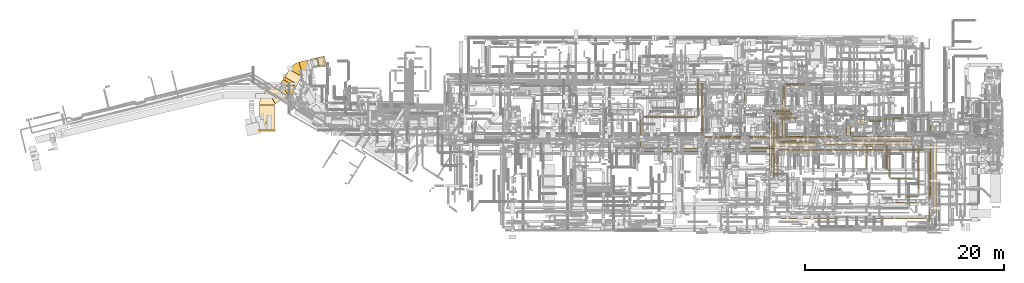
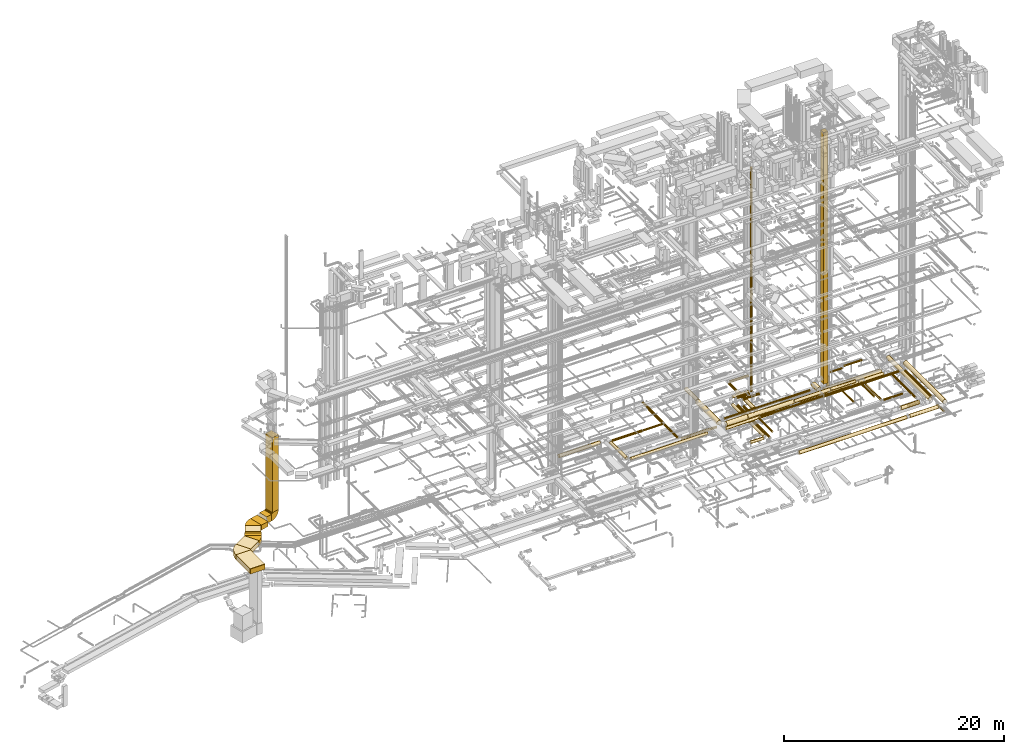
# One storey, part 1 of 337: 65 coverings.
"""IFC2X3 building model written with IfcOpenShell, lengths in millimetres."""

from ifc_helpers import new_model, entity, si_unit, converted_unit, derived_unit, direction, frame, frame_2d, origin, origin_2d_with_axis, place, context, subcontext, project, spatial, polyline, circle_curve, parameter, trimmed, segment, composite_curve, rectangle, circle, outline, extrude, element, save


model = new_model("IFC2X3")

# Units and contexts
model_context = context("Model", 3, precision=0.01, world=origin(), true_north=direction((6.12303176911189e-17, 1.0)))
body_context = subcontext(model_context, "Body", "Model", "MODEL_VIEW")
ifc_project = project(units=[si_unit("LENGTHUNIT", "METRE", prefix="MILLI"), si_unit("AREAUNIT", "SQUARE_METRE"), si_unit("VOLUMEUNIT", "CUBIC_METRE"), converted_unit("PLANEANGLEUNIT", "DEGREE", entity("IfcRatioMeasure", 0.0174532925199433), si_unit("PLANEANGLEUNIT", "RADIAN"), dimensions=[0, 0, 0, 0, 0, 0, 0]), si_unit("MASSUNIT", "GRAM", prefix="KILO"), derived_unit("MASSDENSITYUNIT", [(si_unit("MASSUNIT", "GRAM", prefix="KILO"), 1), (si_unit("LENGTHUNIT", "METRE"), -3)]), derived_unit("MOMENTOFINERTIAUNIT", [(si_unit("LENGTHUNIT", "METRE"), 4)]), si_unit("TIMEUNIT", "SECOND"), si_unit("FREQUENCYUNIT", "HERTZ"), si_unit("THERMODYNAMICTEMPERATUREUNIT", "DEGREE_CELSIUS"), derived_unit("THERMALTRANSMITTANCEUNIT", [(si_unit("MASSUNIT", "GRAM", prefix="KILO"), 1), (si_unit("THERMODYNAMICTEMPERATUREUNIT", "KELVIN"), -1), (si_unit("TIMEUNIT", "SECOND"), -3)]), derived_unit("VOLUMETRICFLOWRATEUNIT", [(si_unit("LENGTHUNIT", "METRE"), 3), (si_unit("TIMEUNIT", "SECOND"), -1)]), derived_unit("MASSFLOWRATEUNIT", [(si_unit("MASSUNIT", "GRAM", prefix="KILO"), 1), (si_unit("TIMEUNIT", "SECOND"), -1)]), derived_unit("ROTATIONALFREQUENCYUNIT", [(si_unit("TIMEUNIT", "SECOND"), -1)]), si_unit("ELECTRICCURRENTUNIT", "AMPERE"), si_unit("ELECTRICVOLTAGEUNIT", "VOLT"), si_unit("POWERUNIT", "WATT"), si_unit("FORCEUNIT", "NEWTON", prefix="KILO"), si_unit("ILLUMINANCEUNIT", "LUX"), si_unit("LUMINOUSFLUXUNIT", "LUMEN"), si_unit("LUMINOUSINTENSITYUNIT", "CANDELA"), derived_unit("USERDEFINED", [(si_unit("MASSUNIT", "GRAM", prefix="KILO"), -1), (si_unit("LENGTHUNIT", "METRE"), -2), (si_unit("TIMEUNIT", "SECOND"), 3), (si_unit("LUMINOUSFLUXUNIT", "LUMEN"), 1)]), derived_unit("LINEARVELOCITYUNIT", [(si_unit("LENGTHUNIT", "METRE"), 1), (si_unit("TIMEUNIT", "SECOND"), -1)]), si_unit("PRESSUREUNIT", "PASCAL"), derived_unit("USERDEFINED", [(si_unit("LENGTHUNIT", "METRE"), -2), (si_unit("MASSUNIT", "GRAM", prefix="KILO"), 1), (si_unit("TIMEUNIT", "SECOND"), -2)]), derived_unit("LINEARFORCEUNIT", [(si_unit("MASSUNIT", "GRAM", prefix="KILO"), 1), (si_unit("LENGTHUNIT", "METRE"), 1), (si_unit("TIMEUNIT", "SECOND"), -2), (si_unit("LENGTHUNIT", "METRE"), -1)]), derived_unit("PLANARFORCEUNIT", [(si_unit("MASSUNIT", "GRAM", prefix="KILO"), 1), (si_unit("LENGTHUNIT", "METRE"), 1), (si_unit("TIMEUNIT", "SECOND"), -2), (si_unit("LENGTHUNIT", "METRE"), -2)])], contexts=[model_context])

# Site, building, storey
site_placement = place(None, origin())
site = spatial("IfcSite", under=ifc_project, at=site_placement, CompositionType="ELEMENT")
building_placement = place(site_placement, origin())
building = spatial("IfcBuilding", under=site, at=building_placement, CompositionType="ELEMENT")
storey_placement = place(building_placement, origin())
storey = spatial("IfcBuildingStorey", under=building, at=storey_placement, CompositionType="ELEMENT", Elevation=0.0)

# Coverings
covering_1_placement = place(storey_placement, frame((31730.09, 12340.89, 3115.9)))
element("IfcCovering", 1, at=covering_1_placement, inside=storey, PredefinedType="INSULATION", context=body_context, shape_type="SweptSolid", body=[
    extrude(circle(Radius=182.5, at=origin_2d_with_axis()), frame((0.0, 184.1, 184.1), z_axis=(1.0, 0.0, 0.0), x_axis=(0.0, -1.0, 0.0)), (0.0, 0.0, 1.0), 4313.00282220616),
])
covering_2_placement = place(storey_placement, frame((46976.82, 8435.07, 3273.4)))
element("IfcCovering", 2, at=covering_2_placement, inside=storey, PredefinedType="INSULATION", context=body_context, shape_type="SweptSolid", body=[
    extrude(circle(Radius=150.0, at=origin_2d_with_axis()), frame((0.0, 151.6, 151.6), z_axis=(1.0, 0.0, 0.0), x_axis=(0.0, -1.0, 0.0)), (0.0, 0.0, 1.0), 3554.57947317912),
])
covering_3_placement = place(storey_placement, frame((50581.4, 8460.07, 3273.4)))
element("IfcCovering", 3, at=covering_3_placement, inside=storey, PredefinedType="INSULATION", context=body_context, shape_type="SweptSolid", body=[
    extrude(circle(Radius=125.0, at=origin_2d_with_axis()), frame((0.0, 126.6, 126.6), z_axis=(1.0, 0.0, 0.0), x_axis=(0.0, 1.0, 0.0)), (0.0, 0.0, 1.0), 14575.0),
])
covering_4_placement = place(storey_placement, frame((36592.96, 8836.67, 3398.4)))
element("IfcCovering", 4, at=covering_4_placement, inside=storey, PredefinedType="INSULATION", context=body_context, shape_type="SweptSolid", body=[
    extrude(circle(Radius=150.0, at=origin_2d_with_axis()), frame((151.6, 0.0, 151.6), z_axis=(0.0, 1.0, 0.0), x_axis=(-1.0, 0.0, 0.0)), (0.0, 0.0, 1.0), 2863.31900942015),
])
covering_5_placement = place(storey_placement, frame((36994.56, 8435.07, 3398.4)))
element("IfcCovering", 5, at=covering_5_placement, inside=storey, PredefinedType="INSULATION", context=body_context, shape_type="SweptSolid", body=[
    extrude(circle(Radius=150.0, at=origin_2d_with_axis()), frame((0.0, 151.6, 151.6), z_axis=(1.0, 0.0, 0.0), x_axis=(0.0, 1.0, 0.0)), (0.0, 0.0, 1.0), 8074.43965571322),
])
covering_6_placement = place(storey_placement, frame((36918.66, 11786.05, 3423.39)))
element("IfcCovering", 6, at=covering_6_placement, inside=storey, PredefinedType="INSULATION", context=body_context, shape_type="SweptSolid", body=[
    extrude(circle(Radius=125.0, at=origin_2d_with_axis()), frame((0.0, 126.6, 126.6), z_axis=(1.0, 0.0, 5.02036912931222e-06), x_axis=(0.0, -1.0, 0.0)), (0.0, 0.0, 1.0), 3218.62203436987),
])
covering_7_placement = place(storey_placement, frame((40177.29, 11806.05, 3443.4)))
element("IfcCovering", 7, at=covering_7_placement, inside=storey, PredefinedType="INSULATION", context=body_context, shape_type="SweptSolid", body=[
    extrude(circle(Radius=105.0, at=origin_2d_with_axis()), frame((0.0, 106.6, 106.6), z_axis=(1.0, 0.0, 0.0), x_axis=(0.0, 1.0, 0.0)), (0.0, 0.0, 1.0), 2101.87500000001),
])
covering_8_placement = place(storey_placement, frame((42332.57, 12072.65, 3443.4)))
element("IfcCovering", 8, at=covering_8_placement, inside=storey, PredefinedType="INSULATION", context=body_context, shape_type="SweptSolid", body=[
    extrude(circle(Radius=105.0, at=origin_2d_with_axis()), frame((106.6, 0.0, 106.6), z_axis=(0.0, 1.0, 0.0), x_axis=(-1.0, 0.0, 0.0)), (0.0, 0.0, 1.0), 3713.75000000001),
])
covering_9_placement = place(storey_placement, frame((50303.25, 6031.67, 3318.4)))
element("IfcCovering", 9, at=covering_9_placement, inside=storey, PredefinedType="INSULATION", context=body_context, shape_type="SweptSolid", body=[
    extrude(circle(Radius=105.0, at=origin_2d_with_axis()), frame((106.6, 0.0, 106.6), z_axis=(0.0, 1.0, 0.0), x_axis=(1.0, 0.0, 0.0)), (0.0, 0.0, 1.0), 2410.00000000047),
])
covering_10_placement = place(storey_placement, frame((57333.53, 10000.0, 2914.23)))
element("IfcCovering", 10, at=covering_10_placement, inside=storey, PredefinedType="INSULATION", context=body_context, shape_type="SweptSolid", body=[
    extrude(circle(Radius=250.0, at=origin_2d_with_axis()), frame((251.6, 0.0, 251.6), z_axis=(0.0, 1.0, 0.0), x_axis=(-1.0, 0.0, 0.0)), (0.0, 0.0, 1.0), 989.573923827316),
])
covering_11_placement = place(storey_placement, frame((42728.53, 10050.0, 2773.4)))
element("IfcCovering", 11, at=covering_11_placement, inside=storey, PredefinedType="INSULATION", context=body_context, shape_type="SweptSolid", body=[
    extrude(circle(Radius=125.0, at=origin_2d_with_axis()), frame((126.6, 0.0, 126.6), z_axis=(0.0, 1.0, 0.0), x_axis=(-1.0, 0.0, 0.0)), (0.0, 0.0, 1.0), 5292.69892382725),
])
covering_12_placement = place(storey_placement, frame((47547.63, 9723.4, 3393.4)))
element("IfcCovering", 12, at=covering_12_placement, inside=storey, PredefinedType="INSULATION", context=body_context, shape_type="SweptSolid", body=[
    extrude(circle(Radius=125.0, at=origin_2d_with_axis()), frame((0.0, 126.6, 126.6), z_axis=(1.0, 0.0, 0.0), x_axis=(0.0, 1.0, 0.0)), (0.0, 0.0, 1.0), 9011.05678366994),
])
covering_13_placement = place(storey_placement, frame((43055.12, 9723.4, 2773.4)))
element("IfcCovering", 13, at=covering_13_placement, inside=storey, PredefinedType="INSULATION", context=body_context, shape_type="SweptSolid", body=[
    extrude(circle(Radius=125.0, at=origin_2d_with_axis()), frame((0.0, 126.6, 126.6), z_axis=(1.0, 0.0, 0.0), x_axis=(0.0, 1.0, 0.0)), (0.0, 0.0, 1.0), 3706.82348043657),
])
covering_14_placement = place(storey_placement, frame((59430.69, 11689.2, 750.0)))
element("IfcCovering", 14, at=covering_14_placement, inside=storey, PredefinedType="INSULATION", context=body_context, shape_type="SweptSolid", body=[
    extrude(rectangle(XDim=249.999999999995, YDim=249.999999999999, at=origin_2d_with_axis()), frame((125.0, 125.0, 0.0), z_axis=(0.0, 0.0, 1.0), x_axis=(-1.0, 0.0, 0.0)), (0.0, 0.0, 1.0), 2145.39989840011),
])
covering_15_placement = place(storey_placement, frame((59650.02, 11448.3, 3373.4)))
element("IfcCovering", 15, at=covering_15_placement, inside=storey, PredefinedType="INSULATION", context=body_context, shape_type="SweptSolid", body=[
    extrude(circle(Radius=75.0, at=origin_2d_with_axis()), frame((0.0, 76.6, 76.6), z_axis=(1.0, 0.0, 0.0), x_axis=(0.0, 1.0, 0.0)), (0.0, 0.0, 1.0), 1238.31053813384),
])
covering_16_placement = place(storey_placement, frame((61208.87, 11685.99, 3373.4)))
element("IfcCovering", 16, at=covering_16_placement, inside=storey, PredefinedType="INSULATION", context=body_context, shape_type="SweptSolid", body=[
    extrude(circle(Radius=75.0, at=origin_2d_with_axis()), frame((0.0, 76.6, 76.6), z_axis=(1.0, 0.0, 0.0), x_axis=(0.0, 1.0, 0.0)), (0.0, 0.0, 1.0), 1897.16573396702),
])
covering_17_placement = place(storey_placement, frame((48115.0, 5911.56, 2848.4)))
element("IfcCovering", 17, at=covering_17_placement, inside=storey, PredefinedType="INSULATION", context=body_context, shape_type="SweptSolid", body=[
    extrude(circle(Radius=150.0, at=origin_2d_with_axis()), frame((0.0, 151.6, 151.6), z_axis=(1.0, 0.0, 0.0), x_axis=(0.0, -1.0, 0.0)), (0.0, 0.0, 1.0), 1362.54081057491),
])
covering_18_placement = place(storey_placement, frame((49575.95, 6313.16, 2848.4)))
element("IfcCovering", 18, at=covering_18_placement, inside=storey, PredefinedType="INSULATION", context=body_context, shape_type="SweptSolid", body=[
    extrude(circle(Radius=150.0, at=origin_2d_with_axis()), frame((151.6, 0.0, 151.6), z_axis=(0.0, 1.0, 0.0), x_axis=(-1.0, 0.0, 0.0)), (0.0, 0.0, 1.0), 5719.04408657297),
])
covering_19_placement = place(storey_placement, frame((51665.12, 12122.45, 3650.0)))
element("IfcCovering", 19, at=covering_19_placement, inside=storey, PredefinedType="INSULATION", context=body_context, shape_type="SweptSolid", body=[
    extrude(circle(Radius=125.0, at=origin_2d_with_axis()), frame((126.6, 126.6, 0.0), z_axis=(0.0, 0.0, 1.0), x_axis=(0.0, -1.0, 0.0)), (0.0, 0.0, 1.0), 24854.3307107923),
])
covering_20_placement = place(storey_placement, frame((49977.54, 12434.16, 3298.4)))
element("IfcCovering", 20, at=covering_20_placement, inside=storey, PredefinedType="INSULATION", context=body_context, shape_type="SweptSolid", body=[
    extrude(circle(Radius=150.0, at=origin_2d_with_axis()), frame((0.0, 151.6, 151.6), z_axis=(1.0, 0.0, 0.0), x_axis=(0.0, -1.0, 0.0)), (0.0, 0.0, 1.0), 1692.31889087023),
])
covering_21_placement = place(storey_placement, frame((50262.54, 12122.45, 3323.4)))
element("IfcCovering", 21, at=covering_21_placement, inside=storey, PredefinedType="INSULATION", context=body_context, shape_type="SweptSolid", body=[
    extrude(circle(Radius=125.0, at=origin_2d_with_axis()), frame((0.0, 126.6, 126.6), z_axis=(1.0, 0.0, 0.0), x_axis=(0.0, -1.0, 0.0)), (0.0, 0.0, 1.0), 1329.17500000001),
])
covering_22_placement = place(storey_placement, frame((50627.16, 9303.36, 2923.4)))
element("IfcCovering", 22, at=covering_22_placement, inside=storey, PredefinedType="INSULATION", context=body_context, shape_type="SweptSolid", body=[
    extrude(circle(Radius=125.0, at=origin_2d_with_axis()), frame((0.0, 126.6, 126.6), z_axis=(1.0, 0.0, 0.0), x_axis=(0.0, 1.0, 0.0)), (0.0, 0.0, 1.0), 3504.75436055232),
])
covering_23_placement = place(storey_placement, frame((50300.56, 9629.95, 2923.4)))
element("IfcCovering", 23, at=covering_23_placement, inside=storey, PredefinedType="INSULATION", context=body_context, shape_type="SweptSolid", body=[
    extrude(circle(Radius=125.0, at=origin_2d_with_axis()), frame((126.6, 0.0, 126.6), z_axis=(0.0, 1.0, 0.0), x_axis=(-1.0, 0.0, 0.0)), (0.0, 0.0, 1.0), 1636.05546720895),
])
covering_24_placement = place(storey_placement, frame((50627.16, 11680.36, 3323.4)))
element("IfcCovering", 24, at=covering_24_placement, inside=storey, PredefinedType="INSULATION", context=body_context, shape_type="SweptSolid", body=[
    extrude(circle(Radius=125.0, at=origin_2d_with_axis()), frame((0.0, 126.6, 126.6), z_axis=(1.0, 0.0, 0.0), x_axis=(0.0, 1.0, 0.0)), (0.0, 0.0, 1.0), 1740.00000000002),
])
covering_25_placement = place(storey_placement, frame((57925.32, 9523.4, 2941.44)))
element("IfcCovering", 25, at=covering_25_placement, inside=storey, PredefinedType="INSULATION", context=body_context, shape_type="SweptSolid", body=[
    extrude(circle(Radius=225.0, at=origin_2d_with_axis()), frame((0.0, 226.6, 226.6), z_axis=(1.0, 0.0, 0.0), x_axis=(0.0, 1.0, 0.0)), (0.0, 0.0, 1.0), 6016.49865140724),
])
covering_26_placement = place(storey_placement, frame((50921.67, 13710.07, 2973.38)))
element("IfcCovering", 26, at=covering_26_placement, inside=storey, PredefinedType="INSULATION", context=body_context, shape_type="SweptSolid", body=[
    extrude(circle(Radius=125.0, at=origin_2d_with_axis()), frame((126.6, 0.0, 126.6), z_axis=(0.0, 1.0, -5.56956099836714e-08), x_axis=(-1.0, 0.0, 0.0)), (0.0, 0.0, 1.0), 1305.00000973617),
])
covering_27_placement = place(storey_placement, frame((51248.26, 15088.48, 2973.38)))
element("IfcCovering", 27, at=covering_27_placement, inside=storey, PredefinedType="INSULATION", context=body_context, shape_type="SweptSolid", body=[
    extrude(circle(Radius=125.0, at=origin_2d_with_axis()), frame((0.0, 126.6, 126.6), z_axis=(1.0, 0.0, 0.0), x_axis=(0.0, -1.0, 0.0)), (0.0, 0.0, 1.0), 1940.00089243215),
])
covering_28_placement = place(storey_placement, frame((61293.27, 9071.79, 2895.9)))
element("IfcCovering", 28, at=covering_28_placement, inside=storey, PredefinedType="INSULATION", context=body_context, shape_type="SweptSolid", body=[
    extrude(circle(Radius=202.5, at=origin_2d_with_axis()), frame((0.0, 204.1, 204.1), z_axis=(1.0, 0.0, 2.15111286707483e-07), x_axis=(0.0, 1.0, 0.0)), (0.0, 0.0, 1.0), 2623.20810251041),
])
covering_29_placement = place(storey_placement, frame((50864.17, 10060.88, 2915.88)))
element("IfcCovering", 29, at=covering_29_placement, inside=storey, PredefinedType="INSULATION", context=body_context, shape_type="SweptSolid", body=[
    extrude(circle(Radius=182.5, at=origin_2d_with_axis()), frame((184.1, 0.0, 184.1), z_axis=(0.0, 1.0, 1.07456912609394e-06), x_axis=(-1.0, 0.0, 0.0)), (0.0, 0.0, 1.0), 3534.18874200155),
])
covering_30_placement = place(storey_placement, frame((51363.26, 9561.79, 2915.88)))
element("IfcCovering", 30, at=covering_30_placement, inside=storey, PredefinedType="INSULATION", context=body_context, shape_type="SweptSolid", body=[
    extrude(circle(Radius=182.5, at=origin_2d_with_axis()), frame((0.0, 184.1, 184.1), z_axis=(1.0, 0.0, 8.92429004954286e-06), x_axis=(0.0, 1.0, 0.0)), (0.0, 0.0, 1.0), 3050.61489077944),
])
covering_31_placement = place(storey_placement, frame((55144.83, 9091.79, 2915.9)))
element("IfcCovering", 31, at=covering_31_placement, inside=storey, PredefinedType="INSULATION", context=body_context, shape_type="SweptSolid", body=[
    extrude(circle(Radius=182.5, at=origin_2d_with_axis()), frame((0.0, 184.1, 184.1), z_axis=(1.0, 0.0, -3.1767587974276e-07), x_axis=(0.0, -1.0, 0.0)), (0.0, 0.0, 1.0), 6108.43145732622),
])
covering_32_placement = place(storey_placement, frame((61331.42, 6625.67, 2993.4)))
element("IfcCovering", 32, at=covering_32_placement, inside=storey, PredefinedType="INSULATION", context=body_context, shape_type="SweptSolid", body=[
    extrude(circle(Radius=105.0, at=origin_2d_with_axis()), frame((106.6, 0.0, 106.6), z_axis=(0.0, 1.0, 0.0), x_axis=(1.0, 0.0, 0.0)), (0.0, 0.0, 1.0), 2452.71541143044),
])
covering_33_placement = place(storey_placement, frame((59297.96, 6750.67, 3010.88)))
element("IfcCovering", 33, at=covering_33_placement, inside=storey, PredefinedType="INSULATION", context=body_context, shape_type="SweptSolid", body=[
    extrude(circle(Radius=87.5, at=origin_2d_with_axis()), frame((89.1, 2347.71, 89.1), z_axis=(0.0, -1.0, 1.21915181881916e-05), x_axis=(-1.0, 0.0, 0.0)), (0.0, 0.0, 1.0), 2347.71334194841),
])
covering_34_placement = place(storey_placement, frame((46738.62, 13552.42, 3365.9)))
element("IfcCovering", 34, at=covering_34_placement, inside=storey, PredefinedType="INSULATION", context=body_context, shape_type="SweptSolid", body=[
    extrude(circle(Radius=182.5, at=origin_2d_with_axis()), frame((184.1, 0.0, 184.1), z_axis=(0.0, 1.0, 0.0), x_axis=(1.0, 0.0, 0.0)), (0.0, 0.0, 1.0), 2110.00000000002),
])
covering_35_placement = place(storey_placement, frame((46603.62, 9558.65, 3248.4)))
element("IfcCovering", 35, at=covering_35_placement, inside=storey, PredefinedType="INSULATION", context=body_context, shape_type="SweptSolid", body=[
    extrude(circle(Radius=250.0, at=origin_2d_with_axis()), frame((251.6, 0.0, 251.6), z_axis=(0.0, 1.0, 0.0), x_axis=(1.0, 0.0, 0.0)), (0.0, 0.0, 1.0), 3858.77143434905),
])
covering_36_placement = place(storey_placement, frame((47305.22, 8857.05, 3248.4)))
element("IfcCovering", 36, at=covering_36_placement, inside=storey, PredefinedType="INSULATION", context=body_context, shape_type="SweptSolid", body=[
    extrude(circle(Radius=250.0, at=origin_2d_with_axis()), frame((0.0, 251.6, 251.6), z_axis=(1.0, 0.0, 0.0), x_axis=(0.0, -1.0, 0.0)), (0.0, 0.0, 1.0), 2205.00000000359),
])
covering_37_placement = place(storey_placement, frame((61620.81, 5891.17, 2993.4)))
element("IfcCovering", 37, at=covering_37_placement, inside=storey, PredefinedType="INSULATION", context=body_context, shape_type="SweptSolid", body=[
    extrude(outline(polyline([(-13.71, -104.1), (13.71, -104.1), (40.18, -97.01), (63.92, -83.3), (83.3, -63.92), (97.01, -40.18), (104.1, -13.71), (104.1, 13.71), (97.01, 40.18), (83.3, 63.92), (63.92, 83.3), (40.18, 97.01), (13.71, 104.1), (-13.71, 104.1), (-40.18, 97.01), (-63.92, 83.3), (-83.3, 63.92), (-97.01, 40.18), (-104.1, 13.71), (-104.1, -13.71), (-97.01, -40.18), (-83.3, -63.92), (-63.92, -83.3), (-40.18, -97.01), (-13.71, -104.1)])), frame((106.6, 0.0, 106.6), z_axis=(8.34410639808837e-09, 1.0, 0.0), x_axis=(-0.130526192220057, 1.08912874587391e-09, -0.99144486137381)), (0.0, 0.0, 1.0), 2751.21031061176),
])
covering_38_placement = place(storey_placement, frame((49560.22, 8882.05, 3273.4)))
element("IfcCovering", 38, at=covering_38_placement, inside=storey, PredefinedType="INSULATION", context=body_context, shape_type="SweptSolid", body=[
    extrude(circle(Radius=225.0, at=origin_2d_with_axis()), frame((0.0, 226.6, 226.6), z_axis=(1.0, 0.0, 4.08186321406273e-07), x_axis=(0.0, -1.0, 0.0)), (0.0, 0.0, 1.0), 4801.18817505093),
])
covering_39_placement = place(storey_placement, frame((58286.4, 8957.05, 3348.43)))
element("IfcCovering", 39, at=covering_39_placement, inside=storey, PredefinedType="INSULATION", context=body_context, shape_type="SweptSolid", body=[
    extrude(circle(Radius=150.0, at=origin_2d_with_axis()), frame((0.0, 151.6, 151.6), z_axis=(1.0, 0.0, -2.03279015452354e-06), x_axis=(0.0, -1.0, 0.0)), (0.0, 0.0, 1.0), 2620.99996522023),
])
covering_40_placement = place(storey_placement, frame((61887.4, 5624.57, 2993.4)))
element("IfcCovering", 40, at=covering_40_placement, inside=storey, PredefinedType="INSULATION", context=body_context, shape_type="SweptSolid", body=[
    extrude(circle(Radius=105.0, at=origin_2d_with_axis()), frame((0.0, 106.6, 106.6), z_axis=(1.0, 0.0, 0.0), x_axis=(0.0, 1.0, 0.0)), (0.0, 0.0, 1.0), 2010.00000000002),
])
covering_41_placement = place(storey_placement, frame((65479.14, 3819.15, 2845.9)))
element("IfcCovering", 41, at=covering_41_placement, inside=storey, PredefinedType="INSULATION", context=body_context, shape_type="SweptSolid", body=[
    extrude(circle(Radius=202.5, at=origin_2d_with_axis()), frame((204.1, 0.0, 204.1), z_axis=(0.0, 1.0, 0.0), x_axis=(-1.0, 0.0, 0.0)), (0.0, 0.0, 1.0), 7615.00000000007),
])
covering_42_placement = place(storey_placement, frame((64541.67, 4649.91, 2943.4)))
element("IfcCovering", 42, at=covering_42_placement, inside=storey, PredefinedType="INSULATION", context=body_context, shape_type="SweptSolid", body=[
    extrude(circle(Radius=105.0, at=origin_2d_with_axis()), frame((106.6, 0.0, 106.6), z_axis=(0.0, 1.0, 0.0), x_axis=(-1.0, 0.0, 0.0)), (0.0, 0.0, 1.0), 4184.99999999999),
])
covering_43_placement = place(storey_placement, frame((63393.27, 3815.82, 2960.9)))
element("IfcCovering", 43, at=covering_43_placement, inside=storey, PredefinedType="INSULATION", context=body_context, shape_type="SweptSolid", body=[
    extrude(circle(Radius=87.5, at=origin_2d_with_axis()), frame((0.0, 89.1, 89.1), z_axis=(1.0, 0.0, 0.0), x_axis=(0.0, -1.0, 0.0)), (0.0, 0.0, 1.0), 1130.0),
])
covering_44_placement = place(storey_placement, frame((66072.37, 2229.37, 3273.4)))
element("IfcCovering", 44, at=covering_44_placement, inside=storey, PredefinedType="INSULATION", context=body_context, shape_type="SweptSolid", body=[
    extrude(circle(Radius=225.0, at=origin_2d_with_axis()), frame((226.6, 0.0, 226.6), z_axis=(0.0, 1.0, 0.0), x_axis=(1.0, 0.0, 0.0)), (0.0, 0.0, 1.0), 7120.63326905055),
])
covering_45_placement = place(storey_placement, frame((65628.08, 3610.46, 3293.4)))
element("IfcCovering", 45, at=covering_45_placement, inside=storey, PredefinedType="INSULATION", context=body_context, shape_type="SweptSolid", body=[
    extrude(circle(Radius=105.0, at=origin_2d_with_axis()), frame((106.6, 0.0, 106.6), z_axis=(0.0, 1.0, 0.0), x_axis=(-1.0, 0.0, 0.0)), (0.0, 0.0, 1.0), 4816.20887710619),
])
covering_46_placement = place(storey_placement, frame((62372.5, 1645.27, 3315.9)))
element("IfcCovering", 46, at=covering_46_placement, inside=storey, PredefinedType="INSULATION", context=body_context, shape_type="SweptSolid", body=[
    extrude(circle(Radius=182.5, at=origin_2d_with_axis()), frame((0.0, 184.1, 184.1), z_axis=(1.0, 0.0, 0.0), x_axis=(0.0, -1.0, 0.0)), (0.0, 0.0, 1.0), 2941.46729274081),
])
covering_47_placement = place(storey_placement, frame((49935.95, 5877.42, 2873.4)))
element("IfcCovering", 47, at=covering_47_placement, inside=storey, PredefinedType="INSULATION", context=body_context, shape_type="SweptSolid", body=[
    extrude(circle(Radius=125.0, at=origin_2d_with_axis()), frame((126.6, 0.0, 126.6), z_axis=(0.0, 1.0, 0.0), x_axis=(1.0, 0.0, 0.0)), (0.0, 0.0, 1.0), 5838.77508624615),
])
covering_48_placement = place(storey_placement, frame((65645.58, 1352.18, 3050.9)))
element("IfcCovering", 48, at=covering_48_placement, inside=storey, PredefinedType="INSULATION", context=body_context, shape_type="SweptSolid", body=[
    extrude(circle(Radius=87.5, at=origin_2d_with_axis()), frame((89.1, 0.0, 89.1), z_axis=(0.0, 1.0, 0.0), x_axis=(1.0, 0.0, 0.0)), (0.0, 0.0, 1.0), 1230.00000000002),
])
covering_49_placement = place(storey_placement, frame((441.35, 14626.6, 3175.0)))
element("IfcCovering", 49, at=covering_49_placement, inside=storey, PredefinedType="INSULATION", context=body_context, shape_type="SweptSolid", body=[
    extrude(rectangle(XDim=340.281662206534, YDim=1550.0, at=origin_2d_with_axis()), frame((756.24, 534.85, 0.0), z_axis=(0.0, 0.0, 1.0), x_axis=(0.499999999999986, 0.866025403784447, 0.0)), (0.0, 0.0, 1.0), 550.0),
])
covering_50_placement = place(storey_placement, frame((611.49, 14921.29, 3175.0)))
element("IfcCovering", 50, at=covering_50_placement, inside=storey, PredefinedType="INSULATION", context=body_context, shape_type="SweptSolid", body=[
    extrude(outline(polyline([(-275.37, -739.8), (28.77, -739.8), (267.15, 690.48), (-20.55, 789.12), (-275.37, -739.8)])), frame((746.17, 517.4, 0.0), z_axis=(0.0, 0.0, 1.0), x_axis=(0.350823262553378, 0.93644168982986, 0.0)), (0.0, 0.0, 1.0), 550.0),
])
covering_51_placement = place(storey_placement, frame((804.79, 15206.1, 3175.0)))
element("IfcCovering", 51, at=covering_51_placement, inside=storey, PredefinedType="INSULATION", context=body_context, shape_type="SweptSolid", body=[
    extrude(rectangle(XDim=894.67269148178, YDim=1450.0, at=origin_2d_with_axis()), frame((851.54, 749.9, 0.0), z_axis=(0.0, 0.0, 1.0), x_axis=(0.49999999999991, 0.866025403784491, 0.0)), (0.0, 0.0, 1.0), 549.999999999999),
])
covering_52_placement = place(storey_placement, frame((2243.11, 16039.85, 3175.0)))
element("IfcCovering", 52, at=covering_52_placement, inside=storey, PredefinedType="INSULATION", context=body_context, shape_type="SweptSolid", body=[
    extrude(rectangle(XDim=823.616881377971, YDim=1450.0, at=origin_2d_with_axis()), frame((571.79, 801.9, 0.0), z_axis=(0.0, 0.0, 1.0), x_axis=(0.971552058141478, 0.236826092990315, 0.0)), (0.0, 0.0, 1.0), 550.0),
])
covering_53_placement = place(storey_placement, frame((3334.65, 16792.21, 3075.0)))
element("IfcCovering", 53, at=covering_53_placement, inside=storey, PredefinedType="INSULATION", context=body_context, shape_type="SweptSolid", body=[
    extrude(rectangle(XDim=614.273800485745, YDim=950.000000000003, at=origin_2d_with_axis()), frame((410.89, 534.23, 0.0), z_axis=(0.0, 0.0, 1.0), x_axis=(0.971552058141473, 0.236826092990338, 0.0)), (0.0, 0.0, 1.0), 750.000000000001),
])
covering_54_placement = place(storey_placement, frame((4052.89, 16967.29, 3950.0)))
element("IfcCovering", 54, at=covering_54_placement, inside=storey, PredefinedType="INSULATION", context=body_context, shape_type="SweptSolid", body=[
    extrude(rectangle(XDim=750.0, YDim=950.000000000001, at=origin_2d_with_axis()), frame((476.82, 550.3, 0.0), z_axis=(0.0, 0.0, 1.0), x_axis=(0.971552058141474, 0.236826092990335, 0.0)), (0.0, 0.0, 1.0), 8300.00000000007),
])
covering_55_placement = place(storey_placement, frame((-937.42, 13243.89, 3175.0)))
element("IfcCovering", 55, at=covering_55_placement, inside=storey, PredefinedType="INSULATION", context=body_context, shape_type="SweptSolid", body=[
    extrude(rectangle(XDim=1539.23048454135, YDim=1550.0, at=origin_2d_with_axis()), frame((1054.01, 1055.98, 0.0), z_axis=(0.0, 0.0, 1.0), x_axis=(-0.866025403784442, -0.499999999999995, 0.0)), (0.0, 0.0, 1.0), 550.000000000001),
])
covering_56_placement = place(storey_placement, frame((-1774.92, 10553.38, 3175.0)))
element("IfcCovering", 56, at=covering_56_placement, inside=storey, PredefinedType="INSULATION", context=body_context, shape_type="SweptSolid", body=[
    extrude(rectangle(XDim=2582.25764801308, YDim=1550.0, at=origin_2d_with_axis()), frame((775.0, 1291.13, 0.0), z_axis=(0.0, 0.0, 1.0), x_axis=(0.0, -1.0, 0.0)), (0.0, 0.0, 1.0), 550.000000000001),
])
covering_57_placement = place(storey_placement, frame((-1774.92, 10503.38, 3175.0)))
element("IfcCovering", 57, at=covering_57_placement, inside=storey, PredefinedType="INSULATION", context=body_context, shape_type="SweptSolid", body=[
    extrude(rectangle(XDim=50.0000000000081, YDim=1550.0, at=origin_2d_with_axis()), frame((775.0, 25.0, 0.0), z_axis=(0.0, 0.0, 1.0), x_axis=(0.0, 1.0, 0.0)), (0.0, 0.0, 1.0), 550.000000000001),
])
covering_58_placement = place(storey_placement, frame((50763.55, 1645.27, 3315.9)))
element("IfcCovering", 58, at=covering_58_placement, inside=storey, PredefinedType="INSULATION", context=body_context, shape_type="SweptSolid", body=[
    extrude(circle(Radius=182.5, at=origin_2d_with_axis()), frame((0.0, 184.1, 184.1), z_axis=(1.0, 0.0, 0.0), x_axis=(0.0, -1.0, 0.0)), (0.0, 0.0, 1.0), 11283.9478056898),
])
covering_59_placement = place(storey_placement, frame((62392.5, 3260.06, 3195.9)))
element("IfcCovering", 59, at=covering_59_placement, inside=storey, PredefinedType="INSULATION", context=body_context, shape_type="SweptSolid", body=[
    extrude(circle(Radius=202.5, at=origin_2d_with_axis()), frame((0.0, 204.1, 204.1), z_axis=(1.0, 0.0, 0.0), x_axis=(0.0, 1.0, 0.0)), (0.0, 0.0, 1.0), 1915.90430928514),
])
covering_60_placement = place(storey_placement, frame((54446.4, 8924.55, 3315.9)))
element("IfcCovering", 60, at=covering_60_placement, inside=storey, PredefinedType="INSULATION", context=body_context, shape_type="SweptSolid", body=[
    extrude(circle(Radius=182.5, at=origin_2d_with_axis()), frame((0.0, 184.1, 184.1), z_axis=(1.0, 0.0, 1.07442470087076e-05), x_axis=(0.0, 1.0, 0.0)), (0.0, 0.0, 1.0), 3775.00011187566),
])
covering_61_placement = place(storey_placement, frame((58754.9, 11164.32, 2620.0)))
element("IfcCovering", 61, at=covering_61_placement, inside=storey, PredefinedType="INSULATION", context=body_context, shape_type="SweptSolid", body=[
    extrude(rectangle(XDim=550.000000000001, YDim=450.000000000001, at=origin_2d_with_axis()), frame((225.01, 275.0, 0.0), z_axis=(-3.89216744281383e-07, 0.0, 1.0), x_axis=(0.0, 1.0, 0.0)), (0.0, 0.0, 1.0), 27930.0045295659),
])
covering_62_placement = place(storey_placement, frame((394.0, 14011.91, 3175.0)))
element("IfcCovering", 62, at=covering_62_placement, inside=storey, PredefinedType="INSULATION", context=body_context, shape_type="SweptSolid", body=[
    extrude(outline(composite_curve([segment(polyline([(-731.46, 162.5), (610.88, -612.5)]), True, "CONTINUOUS"), segment(trimmed(circle_curve(frame_2d((-839.71, 225.0), x_axis=(1.0, 0.0)), 1675.0), [parameter(330.0)], [parameter(0.0)], True, "PARAMETER"), True, "CONTINUOUS"), segment(polyline([(835.29, 225.0), (-714.71, 225.0)]), True, "CONTINUOUS"), segment(trimmed(circle_curve(frame_2d((-839.71, 225.0), x_axis=(1.0, 0.0)), 125.0), [parameter(329.999999999999)], [parameter(360.0)], True, "PARAMETER"), False, "CONTINUOUS")], self_intersect=False)), frame((553.81, 837.48, 0.0), z_axis=(0.0, 0.0, -1.0), x_axis=(0.499999999999995, -0.866025403784441, 0.0)), (0.0, 0.0, -1.0), 550.000000000001),
])
covering_63_placement = place(storey_placement, frame((1250.53, 15979.31, 3175.0)))
element("IfcCovering", 63, at=covering_63_placement, inside=storey, PredefinedType="INSULATION", context=body_context, shape_type="SweptSolid", body=[
    extrude(outline(composite_curve([segment(polyline([(-632.26, 216.89), (369.5, -831.42)]), True, "CONTINUOUS"), segment(trimmed(circle_curve(frame_2d((-718.62, 307.26), x_axis=(1.0, 0.0)), 1575.0), [parameter(313.699289187453)], [parameter(0.0)], True, "PARAMETER"), True, "CONTINUOUS"), segment(polyline([(856.38, 307.26), (-593.62, 307.26)]), True, "CONTINUOUS"), segment(trimmed(circle_curve(frame_2d((-718.62, 307.26), x_axis=(1.0, 0.0)), 125.0), [parameter(313.699289187452)], [parameter(360.0)], True, "PARAMETER"), False, "CONTINUOUS")], self_intersect=False)), frame((896.87, 564.5, 0.0), z_axis=(0.0, 0.0, -1.0), x_axis=(-0.236826092990334, 0.971552058141474, 0.0)), (0.0, 0.0, -1.0), 549.999999999999),
])
covering_64_placement = place(storey_placement, frame((3929.85, 16936.09, 3073.4)))
element("IfcCovering", 64, at=covering_64_placement, inside=storey, PredefinedType="INSULATION", context=body_context, shape_type="SweptSolid", body=[
    extrude(outline(composite_curve([segment(polyline([(-125.0, -250.0), (625.0, -250.0)]), True, "CONTINUOUS"), segment(trimmed(circle_curve(frame_2d((-250.0, -250.0), x_axis=(0.0, 1.0)), 875.0), [parameter(270.0)], [parameter(0.0)], True, "PARAMETER"), True, "CONTINUOUS"), segment(polyline([(-250.0, 625.0), (-250.0, -125.0)]), True, "CONTINUOUS"), segment(trimmed(circle_curve(frame_2d((-250.0, -250.0), x_axis=(0.0, 1.0)), 125.0), [parameter(270.0)], [parameter(360.0)], True, "PARAMETER"), False, "CONTINUOUS")], self_intersect=False)), frame((469.47, 60.8, 626.6), z_axis=(-0.236826092990338, 0.971552058141473, 0.0), x_axis=(0.971552058141473, 0.236826092990338, 0.0)), (0.0, 0.0, 1.0), 950.0),
])
covering_65_placement = place(storey_placement, frame((-1776.51, 13134.04, 3175.0)))
element("IfcCovering", 65, at=covering_65_placement, inside=storey, PredefinedType="INSULATION", context=body_context, shape_type="SweptSolid", body=[
    extrude(outline(composite_curve([segment(polyline([(-612.5, 281.46), (162.5, -1060.88)]), True, "CONTINUOUS"), segment(trimmed(circle_curve(frame_2d((-675.0, 389.71), x_axis=(1.0, 0.0)), 1675.0), [parameter(300.0)], [parameter(0.0)], True, "PARAMETER"), True, "CONTINUOUS"), segment(polyline([(1000.0, 389.71), (-550.0, 389.71)]), True, "CONTINUOUS"), segment(trimmed(circle_curve(frame_2d((-675.0, 389.71), x_axis=(1.0, 0.0)), 125.0), [parameter(300.0)], [parameter(360.0)], True, "PARAMETER"), False, "CONTINUOUS")], self_intersect=False)), frame((1001.6, 391.31, 0.0), z_axis=(0.0, 0.0, -1.0), x_axis=(-0.5, 0.866025403784439, 0.0)), (0.0, 0.0, -1.0), 550.000000000001),
])

save(model, "model.ifc")
